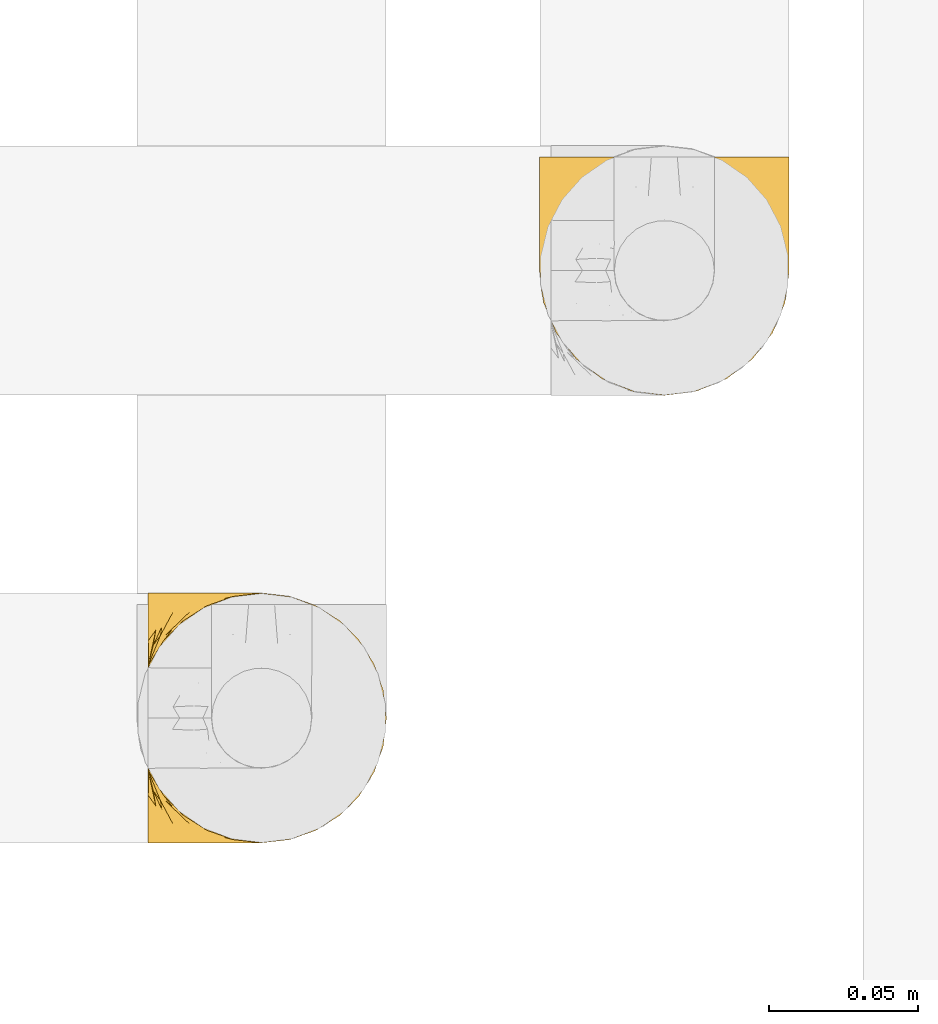
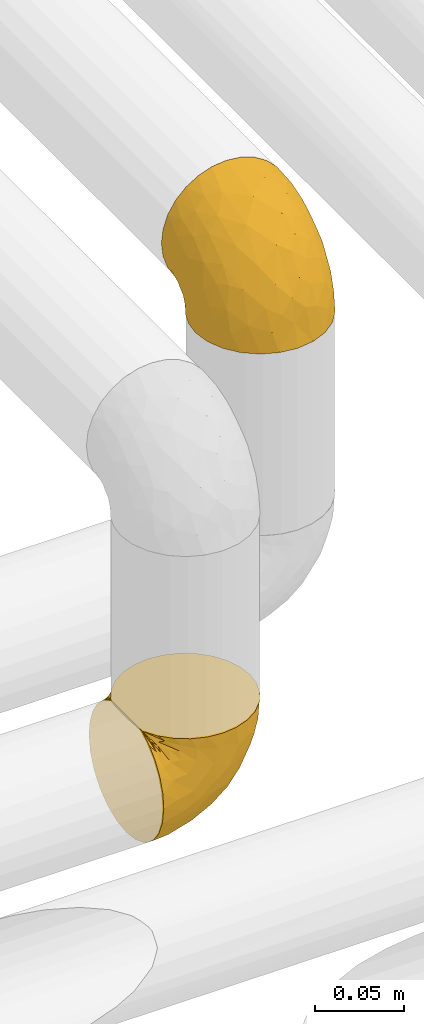
# One storey, part 92 of 827: 2 coverings.
"""IFC2X3 building model written with IfcOpenShell, lengths in millimetres."""

from ifc_helpers import new_model, entity, si_unit, converted_unit, derived_unit, direction, frame, origin, place, context, subcontext, project, spatial, faceted_brep, element, save


model = new_model("IFC2X3")

# Units and contexts
model_context = context("Model", 3, precision=0.01, world=origin(), true_north=direction((6.12303176911189e-17, 1.0)))
body_context = subcontext(model_context, "Body", "Model", "MODEL_VIEW")
ifc_project = project(units=[si_unit("LENGTHUNIT", "METRE", prefix="MILLI"), si_unit("AREAUNIT", "SQUARE_METRE"), si_unit("VOLUMEUNIT", "CUBIC_METRE"), converted_unit("PLANEANGLEUNIT", "DEGREE", entity("IfcRatioMeasure", 0.0174532925199433), si_unit("PLANEANGLEUNIT", "RADIAN"), dimensions=[0, 0, 0, 0, 0, 0, 0]), si_unit("MASSUNIT", "GRAM", prefix="KILO"), derived_unit("MASSDENSITYUNIT", [(si_unit("MASSUNIT", "GRAM", prefix="KILO"), 1), (si_unit("LENGTHUNIT", "METRE"), -3)]), derived_unit("MOMENTOFINERTIAUNIT", [(si_unit("LENGTHUNIT", "METRE"), 4)]), si_unit("TIMEUNIT", "SECOND"), si_unit("FREQUENCYUNIT", "HERTZ"), si_unit("THERMODYNAMICTEMPERATUREUNIT", "DEGREE_CELSIUS"), derived_unit("THERMALTRANSMITTANCEUNIT", [(si_unit("MASSUNIT", "GRAM", prefix="KILO"), 1), (si_unit("THERMODYNAMICTEMPERATUREUNIT", "KELVIN"), -1), (si_unit("TIMEUNIT", "SECOND"), -3)]), derived_unit("VOLUMETRICFLOWRATEUNIT", [(si_unit("LENGTHUNIT", "METRE"), 3), (si_unit("TIMEUNIT", "SECOND"), -1)]), derived_unit("MASSFLOWRATEUNIT", [(si_unit("MASSUNIT", "GRAM", prefix="KILO"), 1), (si_unit("TIMEUNIT", "SECOND"), -1)]), derived_unit("ROTATIONALFREQUENCYUNIT", [(si_unit("TIMEUNIT", "SECOND"), -1)]), si_unit("ELECTRICCURRENTUNIT", "AMPERE"), si_unit("ELECTRICVOLTAGEUNIT", "VOLT"), si_unit("POWERUNIT", "WATT"), si_unit("FORCEUNIT", "NEWTON", prefix="KILO"), si_unit("ILLUMINANCEUNIT", "LUX"), si_unit("LUMINOUSFLUXUNIT", "LUMEN"), si_unit("LUMINOUSINTENSITYUNIT", "CANDELA"), derived_unit("USERDEFINED", [(si_unit("MASSUNIT", "GRAM", prefix="KILO"), -1), (si_unit("LENGTHUNIT", "METRE"), -2), (si_unit("TIMEUNIT", "SECOND"), 3), (si_unit("LUMINOUSFLUXUNIT", "LUMEN"), 1)]), derived_unit("LINEARVELOCITYUNIT", [(si_unit("LENGTHUNIT", "METRE"), 1), (si_unit("TIMEUNIT", "SECOND"), -1)]), si_unit("PRESSUREUNIT", "PASCAL"), derived_unit("USERDEFINED", [(si_unit("LENGTHUNIT", "METRE"), -2), (si_unit("MASSUNIT", "GRAM", prefix="KILO"), 1), (si_unit("TIMEUNIT", "SECOND"), -2)]), derived_unit("LINEARFORCEUNIT", [(si_unit("MASSUNIT", "GRAM", prefix="KILO"), 1), (si_unit("LENGTHUNIT", "METRE"), 1), (si_unit("TIMEUNIT", "SECOND"), -2), (si_unit("LENGTHUNIT", "METRE"), -1)]), derived_unit("PLANARFORCEUNIT", [(si_unit("MASSUNIT", "GRAM", prefix="KILO"), 1), (si_unit("LENGTHUNIT", "METRE"), 1), (si_unit("TIMEUNIT", "SECOND"), -2), (si_unit("LENGTHUNIT", "METRE"), -2)])], contexts=[model_context])

# Site, building, storey
site_placement = place(None, origin())
site = spatial("IfcSite", under=ifc_project, at=site_placement, CompositionType="ELEMENT")
building_placement = place(site_placement, origin())
building = spatial("IfcBuilding", under=site, at=building_placement, CompositionType="ELEMENT")
storey_placement = place(building_placement, frame((0.0, 0.0, 28200.0)))
storey = spatial("IfcBuildingStorey", under=building, at=storey_placement, Name="08", CompositionType="ELEMENT", Elevation=28200.0)

# Coverings
covering_1_placement = place(storey_placement, frame((18305.94, 13056.55, 2356.17)))
element("IfcCovering", 1, at=covering_1_placement, inside=storey, Name=":ADSK_", ObjectType=":ADSK_", PredefinedType="INSULATION", context=body_context, shape_type="Brep", body=[
    faceted_brep([(57.77, 5.74, 81.45), (65.71, 10.73, 81.45), (72.33, 17.36, 81.45), (77.32, 25.29, 81.45), (80.41, 34.14, 81.45), (81.46, 43.45, 81.45), (80.41, 52.76, 81.45), (77.31, 61.61, 81.45), (72.32, 69.54, 81.45), (65.7, 76.17, 81.45), (57.76, 81.15, 81.45), (48.92, 84.25, 81.45), (39.61, 85.3, 81.45), (30.24, 84.23, 81.45), (21.35, 81.1, 81.45), (13.38, 76.06, 81.45), (6.75, 69.36, 81.45), (1.79, 61.36, 81.45), (1.79, 60.44, 81.45), (1.79, 59.52, 81.45), (1.79, 58.72, 81.45), (1.79, 57.4, 81.45), (1.79, 56.08, 81.45), (1.79, 54.76, 81.45), (1.79, 53.44, 81.45), (1.79, 52.12, 81.45), (1.79, 50.8, 81.45), (1.79, 49.47, 81.45), (1.79, 48.15, 81.45), (1.79, 46.83, 81.45), (1.79, 45.51, 81.45), (1.79, 44.19, 81.45), (1.79, 42.87, 81.45), (1.79, 41.55, 81.45), (1.79, 40.23, 81.45), (1.79, 39.31, 81.45), (1.79, 38.39, 81.45), (1.79, 37.48, 81.45), (1.79, 36.56, 81.45), (1.79, 35.64, 81.45), (1.79, 34.72, 81.45), (1.79, 33.8, 81.45), (1.79, 32.88, 81.45), (1.79, 31.96, 81.45), (1.79, 31.05, 81.45), (1.79, 30.13, 81.45), (1.79, 29.21, 81.45), (1.79, 28.29, 81.45), (1.79, 27.37, 81.45), (1.79, 26.45, 81.45), (1.79, 25.53, 81.45), (6.76, 17.52, 81.45), (13.4, 10.82, 81.45), (21.36, 5.78, 81.45), (30.26, 2.65, 81.45), (39.61, 1.6, 81.45), (48.93, 2.65, 81.45), (1.61, 69.37, 76.3), (1.61, 76.06, 69.67), (1.61, 81.1, 61.7), (1.6, 84.23, 52.81), (1.6, 85.3, 43.45), (1.6, 83.87, 32.61), (1.6, 79.69, 22.52), (1.6, 73.04, 13.85), (1.6, 64.37, 7.2), (1.6, 54.28, 3.02), (1.6, 43.45, 1.6), (1.6, 32.61, 3.02), (1.6, 22.52, 7.2), (1.6, 13.85, 13.85), (1.6, 7.2, 22.52), (1.6, 3.02, 32.61), (1.6, 1.6, 43.45), (1.6, 2.66, 52.81), (1.61, 5.79, 61.7), (1.61, 10.83, 69.67), (1.61, 17.52, 76.3), (1.61, 25.53, 81.27), (1.61, 26.45, 81.27), (1.61, 27.77, 81.27), (1.61, 28.89, 81.27), (1.61, 30.01, 81.27), (1.61, 31.13, 81.27), (1.61, 32.25, 81.27), (1.61, 33.37, 81.27), (1.61, 34.49, 81.27), (1.61, 35.61, 81.27), (1.61, 36.73, 81.27), (1.61, 37.85, 81.27), (1.61, 38.97, 81.27), (1.61, 40.09, 81.27), (1.61, 41.21, 81.27), (1.61, 42.33, 81.27), (1.61, 43.45, 81.27), (1.61, 44.77, 81.27), (1.61, 46.09, 81.27), (1.61, 47.41, 81.27), (1.61, 48.73, 81.27), (1.61, 50.05, 81.27), (1.61, 51.37, 81.27), (1.61, 52.69, 81.27), (1.61, 54.01, 81.27), (1.61, 54.93, 81.27), (1.61, 55.85, 81.27), (1.61, 56.76, 81.27), (1.61, 57.68, 81.27), (1.61, 58.6, 81.27), (1.61, 59.52, 81.27), (1.61, 60.44, 81.27), (1.61, 61.36, 81.27), (1.73, 32.81, 81.31), (1.74, 31.73, 81.33), (1.72, 50.71, 81.31), (1.73, 51.76, 81.32), (1.73, 42.89, 81.31), (1.73, 41.81, 81.32), (1.73, 25.53, 81.32), (1.73, 26.91, 81.32), (1.73, 40.71, 81.32), (1.73, 60.15, 81.32), (1.74, 39.53, 81.32), (1.73, 57.22, 81.32), (1.72, 58.17, 81.3), (1.73, 47.12, 81.32), (1.74, 33.93, 81.33), (1.73, 35.05, 81.31), (1.74, 46.09, 81.33), (1.74, 45.02, 81.32), (1.73, 43.95, 81.32), (1.73, 59.12, 81.32), (1.73, 38.49, 81.31), (1.73, 49.68, 81.32), (1.72, 53.35, 81.31), (1.73, 54.4, 81.32), (1.73, 56.2, 81.32), (1.73, 36.2, 81.32), (1.74, 37.29, 81.33), (1.73, 30.57, 81.32), (1.73, 29.45, 81.31), (1.74, 28.01, 81.33), (1.73, 61.36, 81.32), (1.75, 25.53, 81.36), (1.75, 61.36, 81.36), (1.66, 25.53, 81.29), (1.7, 25.53, 81.3), (1.7, 61.36, 81.3), (1.66, 61.36, 81.29), (1.77, 61.36, 81.4), (1.77, 25.53, 81.4), (1.76, 55.3, 81.35), (1.73, 48.18, 81.31), (8.99, 82.92, 58.5), (37.06, 85.3, 71.94), (24.7, 82.92, 74.57), (15.29, 78.8, 73.93), (16.88, 78.8, 78.18), (6.6, 70.46, 78.04), (5.72, 71.16, 76.23), (11.1, 85.3, 45.99), (10.8, 76.1, 74.01), (4.14, 72.9, 73.57), (6.63, 78.81, 66.65), (9.53, 72.89, 79.09), (6.15, 74.06, 73.14), (17.8, 83.71, 60.34), (20.61, 85.3, 48.53), (23.67, 83.61, 67.22), (34.52, 85.3, 62.44), (15.34, 80.61, 68.67), (27.56, 85.3, 55.49), (3.32, 67.83, 77.84), (9.82, 78.81, 68.16), (37.7, 85.3, 74.31), (67.24, 54.78, 38.78), (76.66, 57.27, 62.1), (75.38, 43.45, 50.88), (14.69, 84.37, 36.55), (10.98, 82.11, 28.25), (22.27, 82.11, 31.54), (56.8, 78.88, 57.26), (60.77, 78.88, 69.99), (67.06, 73.04, 64.58), (53.42, 51.17, 21.63), (58.2, 57.41, 28.57), (68.86, 65.72, 51.97), (24.58, 51.16, 5.72), (21.54, 59.46, 7.42), (78.41, 43.45, 66.14), (14.12, 68.92, 11.35), (18.03, 76.65, 20.13), (36.13, 84.47, 50.64), (23.72, 84.39, 40.37), (44.51, 83.48, 55.38), (51.79, 82.95, 68.51), (73.7, 65.72, 67.48), (45.9, 78.97, 40.78), (34.35, 77.15, 27.86), (35.98, 82.64, 41.52), (56.56, 75.14, 46.11), (60.05, 68.58, 40.32), (63.64, 61.95, 38.35), (34.99, 58.11, 11.84), (29.11, 68.92, 15.77), (40.58, 51.07, 12.55), (32.16, 43.45, 7.67), (58.07, 43.45, 24.98), (66.72, 43.45, 37.93), (47.27, 58.51, 19.39), (16.9, 43.45, 4.64), (52.1, 65.68, 28.09), (41.22, 70.41, 23.73), (49.77, 73.04, 34.03), (45.11, 43.45, 16.32), (44.51, 3.41, 55.37), (35.98, 4.26, 41.52), (45.91, 7.93, 40.79), (24.58, 35.73, 5.72), (21.54, 27.43, 7.42), (35.0, 28.78, 11.84), (29.12, 17.97, 15.77), (14.12, 17.97, 11.35), (18.03, 10.24, 20.13), (40.58, 35.82, 12.55), (53.41, 35.72, 21.63), (47.28, 28.39, 19.39), (56.82, 8.01, 57.26), (60.78, 8.01, 69.99), (51.8, 3.95, 68.51), (52.13, 21.22, 28.11), (41.24, 16.49, 23.73), (11.1, 1.6, 45.99), (14.69, 2.52, 36.55), (23.72, 2.5, 40.37), (37.7, 1.6, 74.31), (22.27, 4.78, 31.54), (10.98, 4.78, 28.25), (67.26, 32.11, 38.8), (76.66, 29.63, 62.11), (68.88, 21.19, 51.98), (73.71, 21.19, 67.49), (67.07, 13.86, 64.58), (20.61, 1.6, 48.53), (49.8, 13.86, 34.04), (60.07, 18.32, 40.33), (56.58, 11.77, 46.12), (34.52, 1.6, 62.44), (34.37, 9.74, 27.86), (37.06, 1.6, 71.94), (58.21, 29.49, 28.58), (36.13, 2.42, 50.64), (27.56, 1.6, 55.49), (63.65, 24.95, 38.35), (8.99, 3.97, 58.5), (23.68, 3.27, 67.22), (24.72, 3.97, 74.57), (15.31, 8.08, 73.92), (4.14, 13.99, 73.57), (6.15, 12.83, 73.14), (4.97, 8.08, 66.19), (9.82, 8.08, 68.16), (3.32, 19.06, 77.84), (5.72, 15.74, 76.23), (9.54, 13.98, 79.08), (6.6, 16.42, 78.04), (16.64, 8.08, 77.18), (15.36, 6.27, 68.66), (10.81, 10.78, 74.0), (17.8, 3.18, 60.34)], [[[0, 1, 2, 3, 4, 5, 6, 7, 8, 9, 10, 11, 12, 13, 14, 15, 16, 17, 18, 19, 20, 21, 22, 23, 24, 25, 26, 27, 28, 29, 30, 31, 32, 33, 34, 35, 36, 37, 38, 39, 40, 41, 42, 43, 44, 45, 46, 47, 48, 49, 50, 51, 52, 53, 54, 55, 56]], [[57, 58, 59, 60, 61, 62, 63, 64, 65, 66, 67, 68, 69, 70, 71, 72, 73, 74, 75, 76, 77, 78, 79, 80, 81, 82, 83, 84, 85, 86, 87, 88, 89, 90, 91, 92, 93, 94, 95, 96, 97, 98, 99, 100, 101, 102, 103, 104, 105, 106, 107, 108, 109, 110]], [[111, 84, 112]], [[113, 26, 114]], [[114, 101, 100]], [[115, 93, 116]], [[79, 117, 118]], [[33, 116, 119]], [[117, 49, 118]], [[19, 18, 120]], [[119, 121, 34]], [[122, 21, 123]], [[97, 96, 124]], [[86, 125, 126]], [[116, 92, 119]], [[127, 96, 128]], [[32, 129, 115]], [[19, 120, 130]], [[121, 90, 131]], [[94, 115, 129]], [[115, 116, 32]], [[118, 49, 48]], [[113, 99, 132]], [[133, 114, 25]], [[24, 134, 133]], [[135, 22, 122]], [[136, 137, 88]], [[84, 83, 112]], [[138, 82, 139]], [[130, 20, 19]], [[118, 48, 140]], [[81, 140, 139]], [[123, 21, 20]], [[141, 120, 18]], [[139, 82, 81]], [[130, 107, 123]], [[49, 117, 142]], [[18, 143, 141]], [[79, 78, 144, 145, 117]], [[109, 141, 146, 147, 110]], [[102, 133, 134]], [[105, 135, 122]], [[118, 80, 79]], [[80, 118, 140]], [[18, 17, 148]], [[49, 149, 50]], [[120, 109, 108]], [[47, 46, 140, 48]], [[81, 80, 140]], [[44, 112, 138]], [[93, 115, 94]], [[46, 139, 140]], [[46, 45, 139]], [[139, 45, 138]], [[138, 112, 83]], [[85, 84, 111]], [[112, 43, 111]], [[83, 82, 138]], [[106, 122, 123]], [[105, 122, 106]], [[21, 122, 22]], [[124, 29, 28]], [[33, 32, 116]], [[128, 129, 31]], [[32, 31, 129]], [[34, 33, 119]], [[116, 93, 92]], [[129, 95, 94]], [[95, 129, 128]], [[41, 40, 125, 42]], [[119, 91, 121]], [[36, 35, 131, 37]], [[137, 131, 89]], [[121, 131, 35]], [[90, 121, 91]], [[119, 92, 91]], [[136, 126, 39]], [[125, 86, 85]], [[42, 125, 111]], [[85, 111, 125]], [[150, 23, 22]], [[130, 108, 107]], [[130, 123, 20]], [[107, 106, 123]], [[137, 37, 131]], [[136, 38, 137]], [[89, 88, 137]], [[131, 90, 89]], [[124, 151, 97]], [[40, 39, 126]], [[87, 126, 136]], [[86, 126, 87]], [[136, 88, 87]], [[40, 126, 125]], [[39, 38, 136]], [[95, 128, 96]], [[30, 128, 31]], [[29, 124, 127]], [[127, 128, 30]], [[151, 124, 28]], [[127, 30, 29]], [[127, 124, 96]], [[151, 98, 97]], [[45, 44, 138]], [[26, 113, 132]], [[113, 100, 99]], [[132, 151, 27]], [[27, 26, 132]], [[26, 25, 114]], [[100, 113, 114]], [[101, 133, 102]], [[133, 101, 114]], [[28, 27, 151]], [[132, 99, 98]], [[23, 134, 24]], [[25, 24, 133]], [[134, 23, 150]], [[135, 104, 150]], [[150, 104, 103]], [[103, 102, 134]], [[130, 120, 108]], [[109, 120, 141]], [[42, 111, 43]], [[112, 44, 43]], [[104, 135, 105]], [[134, 150, 103]], [[135, 150, 22]], [[35, 34, 121]], [[137, 38, 37]], [[98, 151, 132]], [[59, 152, 60]], [[13, 153, 154]], [[155, 156, 154]], [[157, 158, 141]], [[159, 60, 152]], [[160, 157, 155]], [[161, 162, 58]], [[58, 162, 59]], [[148, 16, 163]], [[58, 57, 161]], [[162, 161, 164]], [[157, 163, 155]], [[163, 16, 15]], [[57, 147, 161]], [[152, 165, 166]], [[157, 148, 163]], [[159, 61, 60]], [[156, 14, 154]], [[163, 156, 155]], [[155, 154, 167]], [[167, 154, 168]], [[155, 169, 160]], [[57, 110, 147]], [[148, 17, 16]], [[156, 15, 14]], [[170, 165, 167]], [[158, 164, 171]], [[14, 13, 154]], [[157, 143, 148]], [[172, 164, 158]], [[172, 160, 169]], [[170, 166, 165]], [[167, 165, 169]], [[167, 168, 170]], [[152, 172, 165]], [[169, 155, 167]], [[165, 172, 169]], [[160, 172, 158]], [[171, 147, 146]], [[146, 141, 158]], [[158, 157, 160]], [[152, 166, 159]], [[172, 152, 162]], [[59, 162, 152]], [[13, 12, 173, 153]], [[153, 168, 154]], [[15, 156, 163]], [[157, 141, 143]], [[162, 164, 172]], [[171, 164, 161]], [[147, 171, 161]], [[158, 171, 146]], [[174, 175, 176]], [[61, 159, 177]], [[178, 63, 62]], [[177, 179, 178]], [[180, 181, 182]], [[174, 183, 184]], [[173, 12, 11]], [[185, 175, 174]], [[186, 66, 187]], [[175, 6, 188]], [[189, 65, 64]], [[190, 64, 63]], [[65, 187, 66]], [[65, 189, 187]], [[190, 63, 178]], [[170, 191, 192]], [[193, 168, 194]], [[173, 11, 194]], [[8, 7, 195]], [[182, 9, 8]], [[194, 168, 153, 173]], [[194, 11, 10]], [[181, 194, 10]], [[196, 197, 198]], [[194, 180, 193]], [[199, 185, 200]], [[199, 182, 185]], [[184, 201, 174]], [[187, 202, 186]], [[175, 7, 6]], [[176, 175, 188]], [[185, 195, 175]], [[203, 190, 197]], [[195, 182, 8]], [[204, 205, 186]], [[9, 181, 10]], [[197, 190, 179]], [[206, 174, 176, 207]], [[159, 192, 177]], [[189, 190, 203]], [[203, 208, 202]], [[66, 186, 209]], [[210, 211, 212]], [[186, 202, 204]], [[193, 180, 196]], [[193, 198, 191]], [[6, 5, 188]], [[175, 195, 7]], [[182, 195, 185]], [[182, 181, 9]], [[194, 181, 180]], [[198, 197, 179]], [[197, 212, 211]], [[192, 179, 177]], [[180, 199, 196]], [[209, 186, 205]], [[209, 67, 66]], [[204, 202, 208]], [[183, 204, 208]], [[183, 213, 204]], [[184, 183, 208]], [[206, 183, 174]], [[208, 210, 184]], [[200, 201, 210]], [[211, 208, 203]], [[200, 210, 212]], [[199, 200, 212]], [[185, 174, 201]], [[196, 199, 212]], [[182, 199, 180]], [[197, 196, 212]], [[193, 196, 198]], [[210, 201, 184]], [[185, 201, 200]], [[208, 211, 210]], [[197, 211, 203]], [[213, 183, 206]], [[213, 205, 204]], [[193, 191, 168]], [[203, 202, 187]], [[190, 189, 64]], [[187, 189, 203]], [[62, 61, 177]], [[190, 178, 179]], [[62, 177, 178]], [[192, 159, 166]], [[170, 192, 166]], [[198, 179, 192]], [[192, 191, 198]], [[168, 191, 170]], [[214, 215, 216]], [[205, 217, 209]], [[218, 219, 220]], [[218, 220, 221]], [[222, 71, 70]], [[223, 224, 225]], [[226, 227, 228]], [[229, 230, 225]], [[231, 232, 233]], [[56, 234, 228]], [[222, 235, 236]], [[56, 55, 234]], [[72, 236, 232]], [[236, 72, 71]], [[0, 56, 228]], [[69, 68, 218]], [[237, 176, 238]], [[221, 222, 70]], [[239, 240, 241]], [[1, 241, 2]], [[69, 221, 70]], [[238, 3, 240]], [[238, 188, 4]], [[1, 0, 227]], [[241, 240, 2]], [[233, 242, 231]], [[243, 244, 245]], [[226, 228, 214]], [[228, 246, 214]], [[3, 238, 4]], [[222, 247, 235]], [[227, 241, 1]], [[237, 238, 239]], [[241, 226, 245]], [[244, 243, 229]], [[3, 2, 240]], [[237, 206, 207, 176]], [[228, 234, 248, 246]], [[72, 232, 73]], [[220, 230, 247]], [[68, 209, 217]], [[223, 225, 219]], [[223, 219, 217]], [[225, 224, 249]], [[250, 246, 251]], [[215, 235, 247]], [[188, 238, 176]], [[188, 5, 4]], [[238, 240, 239]], [[228, 227, 0]], [[241, 227, 226]], [[220, 247, 222]], [[245, 216, 243]], [[216, 247, 243]], [[214, 250, 215]], [[68, 67, 209]], [[217, 205, 223]], [[68, 217, 218]], [[224, 213, 206]], [[213, 224, 223]], [[246, 250, 214]], [[249, 224, 237]], [[252, 239, 244]], [[229, 225, 249]], [[249, 237, 252]], [[230, 229, 243]], [[252, 229, 249]], [[239, 241, 245]], [[245, 244, 239]], [[226, 214, 216]], [[216, 245, 226]], [[247, 216, 215]], [[239, 252, 237]], [[229, 252, 244]], [[247, 230, 243]], [[225, 230, 220]], [[223, 205, 213]], [[220, 219, 225]], [[233, 251, 242]], [[217, 219, 218]], [[218, 221, 69]], [[222, 221, 220]], [[222, 236, 71]], [[232, 236, 235]], [[232, 235, 233]], [[232, 231, 73]], [[235, 215, 233]], [[233, 215, 250]], [[206, 237, 224]], [[233, 250, 251]], [[74, 231, 253]], [[254, 255, 256]], [[144, 77, 257]], [[258, 259, 260]], [[261, 257, 258]], [[261, 262, 145]], [[75, 74, 253]], [[51, 149, 263]], [[264, 149, 142, 117]], [[257, 77, 76]], [[253, 259, 75]], [[254, 246, 255]], [[255, 248, 54]], [[259, 257, 76]], [[53, 52, 265]], [[256, 266, 254]], [[255, 265, 256]], [[256, 265, 263]], [[75, 259, 76]], [[266, 256, 267]], [[256, 263, 264]], [[51, 50, 149]], [[54, 248, 234, 55]], [[51, 263, 52]], [[254, 268, 251]], [[255, 54, 53]], [[267, 260, 266]], [[144, 78, 77]], [[264, 117, 262]], [[144, 257, 261]], [[258, 260, 262]], [[268, 254, 266]], [[242, 268, 253]], [[251, 268, 242]], [[251, 246, 254]], [[253, 268, 260]], [[256, 264, 267]], [[260, 268, 266]], [[262, 117, 145]], [[264, 262, 267]], [[260, 267, 262]], [[231, 74, 73]], [[231, 242, 253]], [[260, 259, 253]], [[255, 246, 248]], [[53, 265, 255]], [[52, 263, 265]], [[149, 264, 263]], [[259, 258, 257]], [[262, 261, 258]], [[144, 261, 145]], [[49, 142, 149]], [[18, 148, 143]]]),
])
covering_2_placement = place(storey_placement, frame((18437.11, 13206.55, 2560.4)))
element("IfcCovering", 2, at=covering_2_placement, inside=storey, Name=":ADSK_", ObjectType=":ADSK_", PredefinedType="INSULATION", context=body_context, shape_type="Brep", body=[
    faceted_brep([(5.74, 81.45, 57.76), (10.73, 81.45, 65.69), (17.36, 81.45, 72.32), (25.29, 81.45, 77.3), (34.14, 81.45, 80.4), (43.45, 81.45, 81.45), (52.76, 81.45, 80.39), (61.61, 81.45, 77.3), (69.54, 81.45, 72.31), (76.17, 81.45, 65.68), (81.15, 81.45, 57.75), (84.25, 81.45, 48.9), (85.3, 81.45, 39.6), (84.23, 81.45, 30.22), (81.1, 81.45, 21.33), (76.06, 81.45, 13.37), (69.36, 81.45, 6.73), (61.36, 81.45, 1.77), (60.44, 81.45, 1.77), (59.52, 81.45, 1.77), (58.72, 81.45, 1.77), (57.4, 81.45, 1.77), (56.08, 81.45, 1.77), (54.76, 81.45, 1.77), (53.44, 81.45, 1.77), (52.12, 81.45, 1.77), (50.8, 81.45, 1.77), (49.47, 81.45, 1.77), (48.15, 81.45, 1.77), (46.83, 81.45, 1.77), (45.51, 81.45, 1.77), (44.19, 81.45, 1.77), (42.87, 81.45, 1.77), (41.55, 81.45, 1.77), (40.23, 81.45, 1.77), (39.31, 81.45, 1.77), (38.39, 81.45, 1.77), (37.48, 81.45, 1.77), (36.56, 81.45, 1.77), (35.64, 81.45, 1.77), (34.72, 81.45, 1.77), (33.8, 81.45, 1.77), (32.88, 81.45, 1.77), (31.96, 81.45, 1.77), (31.05, 81.45, 1.77), (30.13, 81.45, 1.77), (29.21, 81.45, 1.77), (28.29, 81.45, 1.77), (27.37, 81.45, 1.77), (26.45, 81.45, 1.77), (25.53, 81.45, 1.77), (17.52, 81.45, 6.74), (10.82, 81.45, 13.38), (5.78, 81.45, 21.35), (2.65, 81.45, 30.24), (1.6, 81.45, 39.6), (2.65, 81.45, 48.91), (69.37, 76.3, 1.6), (76.06, 69.67, 1.6), (81.1, 61.7, 1.6), (84.23, 52.81, 1.6), (85.3, 43.45, 1.6), (83.87, 32.61, 1.6), (79.69, 22.52, 1.6), (73.04, 13.85, 1.6), (64.37, 7.2, 1.6), (54.28, 3.02, 1.6), (43.45, 1.6, 1.6), (32.61, 3.02, 1.6), (22.52, 7.2, 1.6), (13.85, 13.85, 1.6), (7.2, 22.52, 1.6), (3.02, 32.61, 1.6), (1.6, 43.45, 1.6), (2.66, 52.81, 1.6), (5.79, 61.7, 1.6), (10.83, 69.67, 1.6), (17.52, 76.3, 1.6), (25.53, 81.27, 1.6), (26.45, 81.27, 1.6), (27.77, 81.27, 1.6), (28.89, 81.27, 1.6), (30.01, 81.27, 1.6), (31.13, 81.27, 1.6), (32.25, 81.27, 1.6), (33.37, 81.27, 1.6), (34.49, 81.27, 1.6), (35.61, 81.27, 1.6), (36.73, 81.27, 1.6), (37.85, 81.27, 1.6), (38.97, 81.27, 1.6), (40.09, 81.27, 1.6), (41.21, 81.27, 1.6), (42.33, 81.27, 1.6), (43.45, 81.27, 1.6), (44.77, 81.27, 1.6), (46.09, 81.27, 1.6), (47.41, 81.27, 1.6), (48.73, 81.27, 1.6), (50.05, 81.27, 1.6), (51.37, 81.27, 1.6), (52.69, 81.27, 1.6), (54.01, 81.27, 1.6), (54.93, 81.27, 1.6), (55.85, 81.27, 1.6), (56.76, 81.27, 1.6), (57.68, 81.27, 1.6), (58.6, 81.27, 1.6), (59.52, 81.27, 1.6), (60.44, 81.27, 1.6), (61.36, 81.27, 1.6), (32.81, 81.31, 1.71), (31.73, 81.33, 1.73), (50.71, 81.31, 1.71), (51.76, 81.32, 1.72), (42.89, 81.31, 1.71), (41.81, 81.32, 1.72), (25.53, 81.32, 1.72), (26.91, 81.32, 1.72), (40.71, 81.32, 1.72), (60.15, 81.32, 1.72), (39.53, 81.32, 1.72), (57.22, 81.32, 1.72), (58.17, 81.3, 1.7), (47.12, 81.32, 1.72), (33.93, 81.33, 1.73), (35.05, 81.31, 1.72), (46.09, 81.33, 1.73), (45.02, 81.32, 1.73), (43.95, 81.32, 1.72), (59.12, 81.32, 1.72), (38.49, 81.31, 1.71), (49.68, 81.32, 1.72), (53.35, 81.31, 1.71), (54.4, 81.32, 1.72), (56.2, 81.32, 1.72), (36.2, 81.32, 1.72), (37.29, 81.33, 1.73), (30.57, 81.32, 1.72), (29.45, 81.31, 1.71), (28.01, 81.33, 1.73), (61.36, 81.32, 1.72), (25.53, 81.36, 1.74), (25.53, 81.4, 1.75), (61.36, 81.4, 1.75), (61.36, 81.36, 1.74), (25.53, 81.29, 1.64), (61.36, 81.3, 1.68), (61.36, 81.29, 1.64), (25.53, 81.3, 1.68), (55.3, 81.35, 1.74), (48.18, 81.31, 1.71), (82.92, 58.5, 8.98), (85.3, 71.95, 37.05), (82.92, 74.57, 24.69), (78.8, 73.93, 15.28), (78.8, 78.18, 16.86), (70.46, 78.04, 6.58), (71.16, 76.23, 5.71), (85.3, 45.99, 11.1), (76.1, 74.01, 10.79), (72.9, 73.57, 4.13), (78.81, 66.66, 6.62), (72.89, 79.09, 9.52), (74.06, 73.14, 6.14), (83.71, 60.34, 17.79), (85.3, 48.54, 20.6), (85.3, 45.36, 8.73), (83.61, 67.22, 23.66), (85.3, 62.45, 34.5), (80.61, 68.67, 15.32), (85.3, 55.49, 27.55), (67.83, 77.84, 3.31), (78.81, 68.16, 9.81), (85.3, 74.31, 37.68), (54.78, 38.78, 67.23), (57.27, 62.1, 76.64), (43.45, 50.89, 75.37), (84.45, 36.91, 14.58), (84.39, 40.37, 23.71), (77.16, 27.86, 34.34), (68.92, 15.77, 29.1), (76.65, 20.13, 18.02), (82.11, 31.54, 22.27), (82.11, 28.25, 10.97), (78.88, 57.26, 56.79), (78.88, 69.99, 60.76), (73.04, 64.58, 67.04), (84.47, 50.64, 36.11), (65.72, 51.97, 68.85), (51.16, 5.72, 24.58), (59.46, 7.42, 21.54), (43.45, 66.14, 78.4), (68.92, 11.35, 14.11), (51.18, 21.64, 53.42), (57.42, 28.57, 58.19), (83.48, 55.38, 44.49), (82.95, 68.51, 51.77), (65.72, 67.48, 73.69), (78.97, 40.78, 45.89), (82.64, 41.53, 35.97), (75.14, 46.11, 56.55), (68.58, 40.32, 60.03), (61.95, 38.36, 63.64), (58.11, 11.84, 34.98), (51.07, 12.56, 40.58), (43.45, 7.67, 32.15), (58.51, 19.39, 47.26), (43.45, 24.98, 58.06), (43.45, 37.94, 66.71), (43.45, 4.64, 16.9), (65.68, 28.09, 52.08), (70.41, 23.73, 41.21), (73.04, 34.03, 49.76), (43.45, 16.33, 45.11), (4.78, 29.29, 15.65), (35.48, 5.77, 24.57), (29.45, 21.44, 50.54), (32.11, 38.8, 67.25), (13.86, 64.58, 67.06), (21.19, 67.49, 73.7), (10.24, 22.9, 26.13), (17.97, 12.54, 19.54), (18.88, 20.04, 38.96), (8.01, 57.26, 56.8), (8.01, 69.99, 60.77), (3.95, 68.51, 51.78), (22.45, 34.54, 59.09), (2.4, 38.81, 19.25), (1.6, 48.54, 20.6), (1.6, 45.99, 11.1), (1.6, 74.31, 37.68), (29.05, 5.36, 15.21), (10.24, 18.96, 12.76), (35.7, 12.79, 40.93), (29.63, 62.11, 76.65), (8.75, 33.14, 39.5), (4.54, 33.44, 25.01), (21.19, 51.98, 68.86), (2.28, 43.42, 26.7), (2.53, 48.62, 34.95), (1.6, 62.45, 34.5), (1.6, 55.49, 27.55), (13.86, 49.68, 61.27), (3.41, 55.37, 44.5), (1.6, 71.95, 37.05), (2.35, 36.37, 10.25), (13.86, 34.04, 49.78), (7.35, 44.1, 47.51), (27.43, 9.99, 29.38), (13.39, 26.41, 40.01), (4.32, 39.19, 33.36), (3.97, 58.5, 8.98), (3.27, 67.22, 23.67), (3.97, 74.57, 24.71), (8.08, 73.92, 15.29), (13.99, 73.57, 4.13), (12.83, 73.14, 6.14), (8.08, 66.19, 4.96), (8.08, 68.16, 9.81), (19.06, 77.84, 3.31), (15.74, 76.23, 5.7), (13.98, 79.08, 9.53), (16.42, 78.04, 6.59), (8.08, 77.18, 16.63), (6.27, 68.66, 15.34), (10.78, 74.0, 10.8), (3.18, 60.34, 17.79)], [[[0, 1, 2, 3, 4, 5, 6, 7, 8, 9, 10, 11, 12, 13, 14, 15, 16, 17, 18, 19, 20, 21, 22, 23, 24, 25, 26, 27, 28, 29, 30, 31, 32, 33, 34, 35, 36, 37, 38, 39, 40, 41, 42, 43, 44, 45, 46, 47, 48, 49, 50, 51, 52, 53, 54, 55, 56]], [[57, 58, 59, 60, 61, 62, 63, 64, 65, 66, 67, 68, 69, 70, 71, 72, 73, 74, 75, 76, 77, 78, 79, 80, 81, 82, 83, 84, 85, 86, 87, 88, 89, 90, 91, 92, 93, 94, 95, 96, 97, 98, 99, 100, 101, 102, 103, 104, 105, 106, 107, 108, 109, 110]], [[111, 84, 112]], [[113, 26, 114]], [[114, 101, 100]], [[115, 93, 116]], [[79, 117, 118]], [[33, 116, 119]], [[117, 49, 118]], [[19, 18, 120]], [[119, 121, 34]], [[122, 21, 123]], [[97, 96, 124]], [[86, 125, 126]], [[116, 92, 119]], [[127, 96, 128]], [[32, 129, 115]], [[19, 120, 130]], [[121, 90, 131]], [[94, 115, 129]], [[115, 116, 32]], [[118, 49, 48]], [[113, 99, 132]], [[133, 114, 25]], [[24, 134, 133]], [[135, 22, 122]], [[136, 137, 88]], [[84, 83, 112]], [[138, 82, 139]], [[130, 20, 19]], [[118, 48, 140]], [[81, 140, 139]], [[123, 21, 20]], [[141, 120, 18]], [[139, 82, 81]], [[130, 107, 123]], [[49, 117, 142, 143, 50]], [[18, 17, 144, 145, 141]], [[79, 78, 146]], [[102, 133, 134]], [[105, 135, 122]], [[109, 141, 147, 148, 110]], [[79, 149, 117]], [[118, 80, 79]], [[80, 118, 140]], [[120, 109, 108]], [[47, 46, 140, 48]], [[81, 80, 140]], [[44, 112, 138]], [[93, 115, 94]], [[46, 139, 140]], [[46, 45, 139]], [[139, 45, 138]], [[138, 112, 83]], [[85, 84, 111]], [[112, 43, 111]], [[83, 82, 138]], [[106, 122, 123]], [[105, 122, 106]], [[21, 122, 22]], [[124, 29, 28]], [[33, 32, 116]], [[128, 129, 31]], [[32, 31, 129]], [[34, 33, 119]], [[116, 93, 92]], [[129, 95, 94]], [[95, 129, 128]], [[41, 40, 125, 42]], [[119, 91, 121]], [[36, 35, 131, 37]], [[137, 131, 89]], [[121, 131, 35]], [[90, 121, 91]], [[119, 92, 91]], [[136, 126, 39]], [[125, 86, 85]], [[42, 125, 111]], [[85, 111, 125]], [[150, 23, 22]], [[130, 108, 107]], [[130, 123, 20]], [[107, 106, 123]], [[137, 37, 131]], [[136, 38, 137]], [[89, 88, 137]], [[131, 90, 89]], [[124, 151, 97]], [[40, 39, 126]], [[87, 126, 136]], [[86, 126, 87]], [[136, 88, 87]], [[40, 126, 125]], [[39, 38, 136]], [[95, 128, 96]], [[30, 128, 31]], [[29, 124, 127]], [[127, 128, 30]], [[151, 124, 28]], [[127, 30, 29]], [[127, 124, 96]], [[151, 98, 97]], [[45, 44, 138]], [[26, 113, 132]], [[113, 100, 99]], [[132, 151, 27]], [[27, 26, 132]], [[26, 25, 114]], [[100, 113, 114]], [[101, 133, 102]], [[133, 101, 114]], [[28, 27, 151]], [[132, 99, 98]], [[23, 134, 24]], [[25, 24, 133]], [[134, 23, 150]], [[135, 104, 150]], [[150, 104, 103]], [[103, 102, 134]], [[130, 120, 108]], [[109, 120, 141]], [[42, 111, 43]], [[112, 44, 43]], [[104, 135, 105]], [[134, 150, 103]], [[135, 150, 22]], [[35, 34, 121]], [[137, 38, 37]], [[98, 151, 132]], [[59, 152, 60]], [[13, 153, 154]], [[155, 156, 154]], [[157, 158, 141]], [[159, 60, 152]], [[160, 157, 155]], [[161, 162, 58]], [[58, 162, 59]], [[144, 16, 163]], [[58, 57, 161]], [[162, 161, 164]], [[157, 163, 155]], [[163, 16, 15]], [[57, 148, 161]], [[152, 165, 166]], [[157, 144, 163]], [[60, 159, 167, 61]], [[156, 14, 154]], [[163, 156, 155]], [[155, 154, 168]], [[168, 154, 169]], [[155, 170, 160]], [[57, 110, 148]], [[144, 17, 16]], [[156, 15, 14]], [[171, 165, 168]], [[158, 164, 172]], [[14, 13, 154]], [[157, 141, 145, 144]], [[173, 164, 158]], [[173, 160, 170]], [[171, 166, 165]], [[168, 165, 170]], [[168, 169, 171]], [[152, 173, 165]], [[170, 155, 168]], [[165, 173, 170]], [[160, 173, 158]], [[172, 148, 147]], [[147, 141, 158]], [[158, 157, 160]], [[152, 166, 159]], [[173, 152, 162]], [[59, 162, 152]], [[13, 12, 174, 153]], [[153, 169, 154]], [[15, 156, 163]], [[162, 164, 173]], [[172, 164, 161]], [[148, 172, 161]], [[158, 172, 147]], [[175, 176, 177]], [[178, 166, 179]], [[180, 181, 182]], [[183, 184, 178]], [[185, 186, 187]], [[171, 188, 179]], [[174, 12, 11]], [[189, 176, 175]], [[190, 66, 191]], [[176, 6, 192]], [[193, 65, 64]], [[63, 184, 182]], [[63, 182, 64]], [[65, 193, 191]], [[184, 63, 62]], [[175, 194, 195]], [[196, 169, 197]], [[174, 11, 197]], [[8, 7, 198]], [[187, 9, 8]], [[197, 169, 153, 174]], [[197, 11, 10]], [[186, 197, 10]], [[199, 180, 200]], [[197, 185, 196]], [[201, 189, 202]], [[201, 187, 189]], [[195, 203, 175]], [[191, 204, 190]], [[176, 7, 6]], [[177, 176, 192]], [[189, 198, 176]], [[65, 191, 66]], [[198, 187, 8]], [[205, 206, 190]], [[9, 186, 10]], [[181, 207, 204]], [[208, 175, 177, 209]], [[66, 190, 210]], [[211, 212, 213]], [[190, 204, 205]], [[180, 182, 183]], [[193, 182, 181]], [[62, 61, 167]], [[196, 185, 199]], [[196, 200, 188]], [[6, 5, 192]], [[176, 198, 7]], [[187, 198, 189]], [[187, 186, 9]], [[197, 186, 185]], [[200, 180, 183]], [[180, 213, 212]], [[179, 183, 178]], [[185, 201, 199]], [[210, 190, 206]], [[210, 67, 66]], [[205, 204, 207]], [[194, 205, 207]], [[194, 214, 205]], [[195, 194, 207]], [[208, 194, 175]], [[207, 211, 195]], [[202, 203, 211]], [[212, 207, 181]], [[202, 211, 213]], [[201, 202, 213]], [[189, 175, 203]], [[199, 201, 213]], [[187, 201, 185]], [[180, 199, 213]], [[196, 199, 200]], [[211, 203, 195]], [[189, 203, 202]], [[207, 212, 211]], [[180, 212, 181]], [[214, 194, 208]], [[214, 206, 205]], [[196, 188, 169]], [[181, 204, 191]], [[182, 193, 64]], [[191, 193, 181]], [[178, 62, 167]], [[182, 184, 183]], [[62, 178, 184]], [[178, 167, 159, 166]], [[171, 179, 166]], [[200, 183, 179]], [[179, 188, 200]], [[169, 188, 171]], [[71, 215, 72]], [[206, 216, 210]], [[217, 208, 218]], [[216, 68, 210]], [[219, 220, 2]], [[221, 222, 223]], [[224, 225, 226]], [[227, 223, 217]], [[228, 229, 230]], [[56, 231, 226]], [[232, 222, 69]], [[56, 55, 231]], [[70, 233, 71]], [[71, 233, 215]], [[0, 56, 226]], [[208, 217, 234]], [[218, 177, 235]], [[221, 236, 237]], [[238, 220, 219]], [[1, 219, 2]], [[68, 216, 232]], [[235, 3, 220]], [[235, 192, 4]], [[1, 0, 225]], [[228, 239, 229]], [[240, 241, 242]], [[243, 238, 219]], [[224, 226, 244]], [[226, 241, 244]], [[3, 235, 4]], [[69, 222, 70]], [[225, 219, 1]], [[218, 235, 238]], [[243, 219, 224]], [[218, 227, 217]], [[3, 2, 220]], [[218, 208, 209, 177]], [[226, 231, 245, 241]], [[215, 228, 246]], [[247, 248, 236]], [[248, 224, 244]], [[223, 222, 249]], [[233, 222, 221]], [[242, 239, 240]], [[248, 247, 243]], [[217, 223, 249]], [[250, 247, 236]], [[216, 234, 249]], [[218, 238, 227]], [[192, 235, 177]], [[192, 5, 4]], [[72, 246, 73]], [[235, 220, 238]], [[226, 225, 0]], [[219, 225, 224]], [[240, 248, 244]], [[239, 242, 229]], [[236, 248, 251]], [[68, 67, 210]], [[234, 216, 206]], [[216, 249, 232]], [[234, 206, 214, 208]], [[249, 234, 217]], [[222, 232, 249]], [[69, 68, 232]], [[246, 228, 230]], [[237, 228, 215]], [[243, 227, 238]], [[223, 227, 247]], [[73, 246, 230]], [[215, 246, 72]], [[248, 243, 224]], [[227, 243, 247]], [[237, 236, 251]], [[250, 221, 223]], [[222, 233, 70]], [[215, 233, 221]], [[221, 237, 215]], [[239, 237, 251]], [[237, 239, 228]], [[239, 251, 240]], [[248, 240, 251]], [[241, 240, 244]], [[221, 250, 236]], [[223, 247, 250]], [[74, 230, 252]], [[253, 254, 255]], [[146, 77, 256]], [[257, 258, 259]], [[260, 256, 257]], [[260, 261, 149]], [[75, 74, 252]], [[51, 143, 262]], [[263, 143, 142, 117]], [[256, 77, 76]], [[252, 258, 75]], [[253, 241, 254]], [[254, 245, 54]], [[258, 256, 76]], [[53, 52, 264]], [[255, 265, 253]], [[254, 264, 255]], [[255, 264, 262]], [[75, 258, 76]], [[265, 255, 266]], [[255, 262, 263]], [[51, 50, 143]], [[54, 245, 231, 55]], [[51, 262, 52]], [[253, 267, 242]], [[254, 54, 53]], [[266, 259, 265]], [[146, 78, 77]], [[263, 117, 261]], [[146, 256, 260]], [[257, 259, 261]], [[267, 253, 265]], [[229, 267, 252]], [[242, 267, 229]], [[242, 241, 253]], [[252, 267, 259]], [[255, 263, 266]], [[259, 267, 265]], [[261, 117, 149]], [[263, 261, 266]], [[259, 266, 261]], [[230, 74, 73]], [[230, 229, 252]], [[259, 258, 252]], [[254, 241, 245]], [[53, 264, 254]], [[52, 262, 264]], [[143, 263, 262]], [[258, 257, 256]], [[261, 260, 257]], [[146, 260, 149]], [[79, 146, 149]]]),
])

save(model, "model.ifc")
